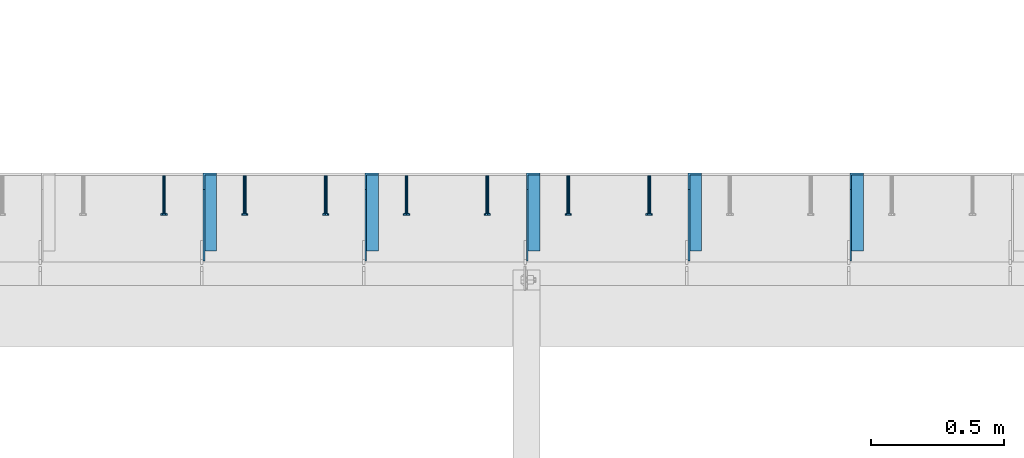
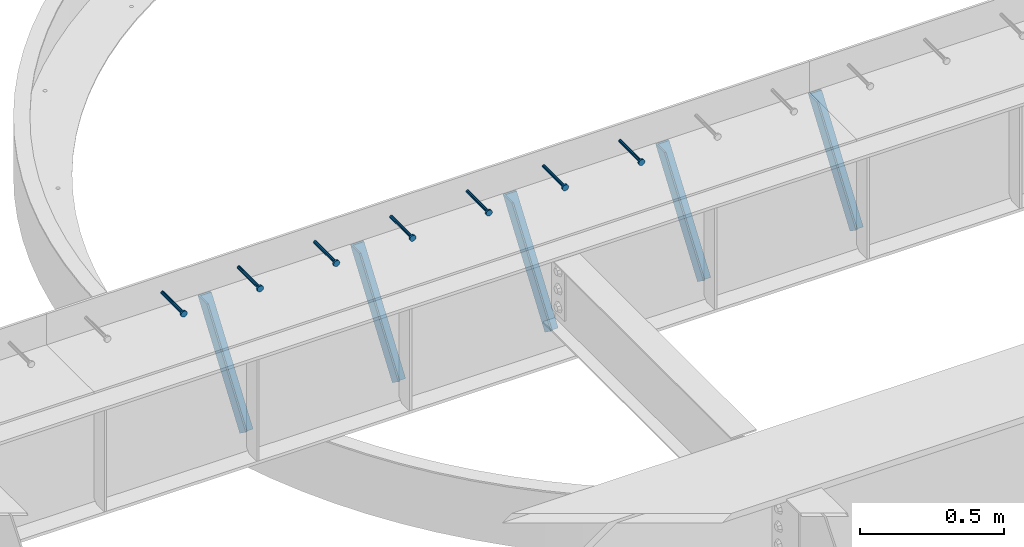
# One storey, part 1349 of 1763: 7 beams, 5 members, 8 elements without a shape of their own.
"""IFC2X3 building model written with IfcOpenShell, lengths in millimetres."""

from ifc_helpers import new_model, si_unit, frame, origin_with_axes, place, context, subcontext, project, spatial, faceted_brep, material, type_object, element, aggregate, save


model = new_model("IFC2X3")

# Units and contexts
model_context = context("Model", 3, precision=1e-05, world=origin_with_axes())
body_context = subcontext(model_context, "Body", "Model", "MODEL_VIEW")
ifc_project = project(units=[si_unit("LENGTHUNIT", "METRE", prefix="MILLI"), si_unit("AREAUNIT", "SQUARE_METRE"), si_unit("VOLUMEUNIT", "CUBIC_METRE"), si_unit("MASSUNIT", "GRAM", prefix="KILO"), si_unit("TIMEUNIT", "SECOND"), si_unit("PLANEANGLEUNIT", "RADIAN"), si_unit("SOLIDANGLEUNIT", "STERADIAN"), si_unit("THERMODYNAMICTEMPERATUREUNIT", "DEGREE_CELSIUS"), si_unit("LUMINOUSINTENSITYUNIT", "LUMEN")], contexts=[model_context])

# Site, building, storey
site_placement = place(None, origin_with_axes())
site = spatial("IfcSite", under=ifc_project, at=site_placement, CompositionType="ELEMENT")
building_placement = place(site_placement, origin_with_axes())
building = spatial("IfcBuilding", under=site, at=building_placement, Name="Undefined", CompositionType="ELEMENT")
storey_placement = place(building_placement, origin_with_axes())
storey = spatial("IfcBuildingStorey", under=building, at=storey_placement, Name="Undefined", CompositionType="ELEMENT", Elevation=0.0)

# Assembly, beam
assembly_1_placement = place(storey_placement, origin_with_axes())
assembly_1 = element("IfcElementAssembly", 1, at=assembly_1_placement, inside=storey, Name="HEADED STUD ANCHOR", AssemblyPlace="NOTDEFINED", PredefinedType="RIGID_FRAME")
ifc_material_1 = material(Name="STEEL/A108")
beam_type = type_object("IfcBeamType", PredefinedType="NOTDEFINED")
beam_1_placement = place(assembly_1_placement, frame((-56255.6747736983, 53984.5250183106, 5264.23140606069), z_axis=(0.0, 0.0, 1.0), x_axis=(0.0, -1.0, 0.0)))
beam_1 = element("IfcBeam", 2, at=beam_1_placement, type_object=beam_type, material=ifc_material_1, Name="HEADED STUD ANCHOR", context=body_context, shape_type="Brep", body=[
    faceted_brep([(0.0, -3.1800000667572, 5.5), (0.0, -5.5, 3.1800000667572), (141.732000000002, -5.5, 3.1800000667572), (141.732000000002, -3.1800000667572, 5.5), (0.0, -6.34999999999491, 1.45519152283669e-11), (141.732000000002, -6.34999990463257, 0.0), (0.0, -5.5, -3.1800000667572), (141.732000000002, -5.5, -3.1800000667572), (0.0, -3.1800000667572, -5.5), (141.732000000002, -3.1800000667572, -5.5), (0.0, 0.0, -6.34999990463257), (141.732000000002, 0.0, -6.34999990463257), (0.0, 3.1800000667572, -5.5), (141.732000000002, 3.1800000667572, -5.5), (0.0, 5.5, -3.1800000667572), (141.732000000002, 5.5, -3.1800000667572), (0.0, 6.34999999999491, -2.91038304567337e-11), (141.732000000002, 6.34999990463257, 0.0), (0.0, 5.5, 3.1800000667572), (141.732000000002, 5.5, 3.1800000667572), (0.0, 3.1800000667572, 5.5), (141.732000000002, 3.1800000667572, 5.5), (0.0, 0.0, 6.34999990463257), (141.732000000002, 0.0, 6.34999990463257), (144.780000000001, -10.9899997711182, 6.34999990463257), (144.780000000001, -6.34000015258789, 10.9899997711182), (144.780000000001, -12.6999998092651, 0.0), (144.780000000001, -10.9899997711182, -6.34999990463257), (144.780000000001, -6.34000015258789, -10.9899997711182), (144.780000000001, 0.0, -12.6899995803833), (144.780000000001, 6.34000015258789, -10.9899997711182), (144.780000000001, 10.9899997711182, -6.34999990463257), (144.780000000001, 12.6999998092651, 0.0), (144.780000000001, 10.9899997711182, 6.34999990463257), (144.780000000001, 6.34000015258789, 10.9899997711182), (144.780000000001, 0.0, 12.6899995803833), (152.400000000001, -10.9899997711182, 6.34999990463257), (152.400000000001, -6.34000015258789, 10.9899997711182), (152.400000000001, -12.6999998092651, 0.0), (152.400000000001, -10.9899997711182, -6.34999990463257), (152.400000000001, -6.34000015258789, -10.9899997711182), (152.400000000001, 0.0, -12.6899995803833), (152.400000000001, 6.34000015258789, -10.9899997711182), (152.400000000001, 10.9899997711182, -6.34999990463257), (152.400000000001, 12.6999998092651, 0.0), (152.400000000001, 10.9899997711182, 6.34999990463257), (152.400000000001, 6.34000015258789, 10.9899997711182), (152.400000000001, 0.0, 12.6899995803833)], [[[0, 1, 2, 3]], [[1, 4, 5, 2]], [[4, 6, 7, 5]], [[6, 8, 9, 7]], [[8, 10, 11, 9]], [[10, 12, 13, 11]], [[12, 14, 15, 13]], [[14, 16, 17, 15]], [[16, 18, 19, 17]], [[18, 20, 21, 19]], [[20, 22, 23, 21]], [[22, 0, 3, 23]], [[22, 20, 18, 16, 14, 12, 10, 8, 6, 4, 1, 0]], [[3, 2, 24, 25]], [[2, 5, 26, 24]], [[5, 7, 27, 26]], [[7, 9, 28, 27]], [[9, 11, 29, 28]], [[11, 13, 30, 29]], [[13, 15, 31, 30]], [[15, 17, 32, 31]], [[17, 19, 33, 32]], [[19, 21, 34, 33]], [[21, 23, 35, 34]], [[23, 3, 25, 35]], [[25, 24, 36, 37]], [[24, 26, 38, 36]], [[26, 27, 39, 38]], [[27, 28, 40, 39]], [[28, 29, 41, 40]], [[29, 30, 42, 41]], [[30, 31, 43, 42]], [[31, 32, 44, 43]], [[32, 33, 45, 44]], [[33, 34, 46, 45]], [[34, 35, 47, 46]], [[35, 25, 37, 47]], [[38, 39, 40, 41, 42, 43, 44, 45, 46, 47, 37, 36]]]),
])
aggregate(assembly_1, [beam_1])

assembly_2_placement = place(storey_placement, origin_with_axes())
assembly_2 = element("IfcElementAssembly", 3, at=assembly_2_placement, inside=storey, Name="HEADED STUD ANCHOR", AssemblyPlace="NOTDEFINED", PredefinedType="RIGID_FRAME")
beam_2_placement = place(assembly_2_placement, frame((-56560.4747736983, 53984.5250183106, 5264.23140606069), z_axis=(0.0, 0.0, 1.0), x_axis=(0.0, -1.0, 0.0)))
beam_2 = element("IfcBeam", 4, at=beam_2_placement, type_object=beam_type, material=ifc_material_1, Name="HEADED STUD ANCHOR", context=body_context, shape_type="Brep", body=[
    faceted_brep([(0.0, -3.1800000667572, 5.5), (0.0, -5.5, 3.1800000667572), (141.732000000002, -5.5, 3.1800000667572), (141.732000000002, -3.1800000667572, 5.5), (0.0, -6.34999999999491, 1.45519152283669e-11), (141.732000000002, -6.34999990463257, 0.0), (0.0, -5.5, -3.1800000667572), (141.732000000002, -5.5, -3.1800000667572), (0.0, -3.1800000667572, -5.5), (141.732000000002, -3.1800000667572, -5.5), (0.0, 0.0, -6.34999990463257), (141.732000000002, 0.0, -6.34999990463257), (0.0, 3.1800000667572, -5.5), (141.732000000002, 3.1800000667572, -5.5), (0.0, 5.5, -3.1800000667572), (141.732000000002, 5.5, -3.1800000667572), (0.0, 6.34999999999491, -2.91038304567337e-11), (141.732000000002, 6.34999990463257, 0.0), (0.0, 5.5, 3.1800000667572), (141.732000000002, 5.5, 3.1800000667572), (0.0, 3.1800000667572, 5.5), (141.732000000002, 3.1800000667572, 5.5), (0.0, 0.0, 6.34999990463257), (141.732000000002, 0.0, 6.34999990463257), (144.780000000001, -10.9899997711182, 6.34999990463257), (144.780000000001, -6.34000015258789, 10.9899997711182), (144.780000000001, -12.6999998092651, 0.0), (144.780000000001, -10.9899997711182, -6.34999990463257), (144.780000000001, -6.34000015258789, -10.9899997711182), (144.780000000001, 0.0, -12.6899995803833), (144.780000000001, 6.34000015258789, -10.9899997711182), (144.780000000001, 10.9899997711182, -6.34999990463257), (144.780000000001, 12.6999998092651, 0.0), (144.780000000001, 10.9899997711182, 6.34999990463257), (144.780000000001, 6.34000015258789, 10.9899997711182), (144.780000000001, 0.0, 12.6899995803833), (152.400000000001, -10.9899997711182, 6.34999990463257), (152.400000000001, -6.34000015258789, 10.9899997711182), (152.400000000001, -12.6999998092651, 0.0), (152.400000000001, -10.9899997711182, -6.34999990463257), (152.400000000001, -6.34000015258789, -10.9899997711182), (152.400000000001, 0.0, -12.6899995803833), (152.400000000001, 6.34000015258789, -10.9899997711182), (152.400000000001, 10.9899997711182, -6.34999990463257), (152.400000000001, 12.6999998092651, 0.0), (152.400000000001, 10.9899997711182, 6.34999990463257), (152.400000000001, 6.34000015258789, 10.9899997711182), (152.400000000001, 0.0, 12.6899995803833)], [[[0, 1, 2, 3]], [[1, 4, 5, 2]], [[4, 6, 7, 5]], [[6, 8, 9, 7]], [[8, 10, 11, 9]], [[10, 12, 13, 11]], [[12, 14, 15, 13]], [[14, 16, 17, 15]], [[16, 18, 19, 17]], [[18, 20, 21, 19]], [[20, 22, 23, 21]], [[22, 0, 3, 23]], [[22, 20, 18, 16, 14, 12, 10, 8, 6, 4, 1, 0]], [[3, 2, 24, 25]], [[2, 5, 26, 24]], [[5, 7, 27, 26]], [[7, 9, 28, 27]], [[9, 11, 29, 28]], [[11, 13, 30, 29]], [[13, 15, 31, 30]], [[15, 17, 32, 31]], [[17, 19, 33, 32]], [[19, 21, 34, 33]], [[21, 23, 35, 34]], [[23, 3, 25, 35]], [[25, 24, 36, 37]], [[24, 26, 38, 36]], [[26, 27, 39, 38]], [[27, 28, 40, 39]], [[28, 29, 41, 40]], [[29, 30, 42, 41]], [[30, 31, 43, 42]], [[31, 32, 44, 43]], [[32, 33, 45, 44]], [[33, 34, 46, 45]], [[34, 35, 47, 46]], [[35, 25, 37, 47]], [[38, 39, 40, 41, 42, 43, 44, 45, 46, 47, 37, 36]]]),
])
aggregate(assembly_2, [beam_2])

assembly_3_placement = place(storey_placement, origin_with_axes())
assembly_3 = element("IfcElementAssembly", 5, at=assembly_3_placement, inside=storey, Name="HEADED STUD ANCHOR", AssemblyPlace="NOTDEFINED", PredefinedType="RIGID_FRAME")
beam_3_placement = place(assembly_3_placement, frame((-56865.2747736983, 53984.5250183106, 5264.23140606069), z_axis=(0.0, 0.0, 1.0), x_axis=(0.0, -1.0, 0.0)))
beam_3 = element("IfcBeam", 6, at=beam_3_placement, type_object=beam_type, material=ifc_material_1, Name="HEADED STUD ANCHOR", context=body_context, shape_type="Brep", body=[
    faceted_brep([(0.0, -3.1800000667572, 5.5), (0.0, -5.5, 3.1800000667572), (141.732000000002, -5.5, 3.1800000667572), (141.732000000002, -3.1800000667572, 5.5), (0.0, -6.34999999999491, 1.45519152283669e-11), (141.732000000002, -6.34999990463257, 0.0), (0.0, -5.5, -3.1800000667572), (141.732000000002, -5.5, -3.1800000667572), (0.0, -3.1800000667572, -5.5), (141.732000000002, -3.1800000667572, -5.5), (0.0, 0.0, -6.34999990463257), (141.732000000002, 0.0, -6.34999990463257), (0.0, 3.1800000667572, -5.5), (141.732000000002, 3.1800000667572, -5.5), (0.0, 5.5, -3.1800000667572), (141.732000000002, 5.5, -3.1800000667572), (0.0, 6.34999999999491, -2.91038304567337e-11), (141.732000000002, 6.34999990463257, 0.0), (0.0, 5.5, 3.1800000667572), (141.732000000002, 5.5, 3.1800000667572), (0.0, 3.1800000667572, 5.5), (141.732000000002, 3.1800000667572, 5.5), (0.0, 0.0, 6.34999990463257), (141.732000000002, 0.0, 6.34999990463257), (144.780000000001, -10.9899997711182, 6.34999990463257), (144.780000000001, -6.34000015258789, 10.9899997711182), (144.780000000001, -12.6999998092651, 0.0), (144.780000000001, -10.9899997711182, -6.34999990463257), (144.780000000001, -6.34000015258789, -10.9899997711182), (144.780000000001, 0.0, -12.6899995803833), (144.780000000001, 6.34000015258789, -10.9899997711182), (144.780000000001, 10.9899997711182, -6.34999990463257), (144.780000000001, 12.6999998092651, 0.0), (144.780000000001, 10.9899997711182, 6.34999990463257), (144.780000000001, 6.34000015258789, 10.9899997711182), (144.780000000001, 0.0, 12.6899995803833), (152.400000000001, -10.9899997711182, 6.34999990463257), (152.400000000001, -6.34000015258789, 10.9899997711182), (152.400000000001, -12.6999998092651, 0.0), (152.400000000001, -10.9899997711182, -6.34999990463257), (152.400000000001, -6.34000015258789, -10.9899997711182), (152.400000000001, 0.0, -12.6899995803833), (152.400000000001, 6.34000015258789, -10.9899997711182), (152.400000000001, 10.9899997711182, -6.34999990463257), (152.400000000001, 12.6999998092651, 0.0), (152.400000000001, 10.9899997711182, 6.34999990463257), (152.400000000001, 6.34000015258789, 10.9899997711182), (152.400000000001, 0.0, 12.6899995803833)], [[[0, 1, 2, 3]], [[1, 4, 5, 2]], [[4, 6, 7, 5]], [[6, 8, 9, 7]], [[8, 10, 11, 9]], [[10, 12, 13, 11]], [[12, 14, 15, 13]], [[14, 16, 17, 15]], [[16, 18, 19, 17]], [[18, 20, 21, 19]], [[20, 22, 23, 21]], [[22, 0, 3, 23]], [[22, 20, 18, 16, 14, 12, 10, 8, 6, 4, 1, 0]], [[3, 2, 24, 25]], [[2, 5, 26, 24]], [[5, 7, 27, 26]], [[7, 9, 28, 27]], [[9, 11, 29, 28]], [[11, 13, 30, 29]], [[13, 15, 31, 30]], [[15, 17, 32, 31]], [[17, 19, 33, 32]], [[19, 21, 34, 33]], [[21, 23, 35, 34]], [[23, 3, 25, 35]], [[25, 24, 36, 37]], [[24, 26, 38, 36]], [[26, 27, 39, 38]], [[27, 28, 40, 39]], [[28, 29, 41, 40]], [[29, 30, 42, 41]], [[30, 31, 43, 42]], [[31, 32, 44, 43]], [[32, 33, 45, 44]], [[33, 34, 46, 45]], [[34, 35, 47, 46]], [[35, 25, 37, 47]], [[38, 39, 40, 41, 42, 43, 44, 45, 46, 47, 37, 36]]]),
])
aggregate(assembly_3, [beam_3])

assembly_4_placement = place(storey_placement, origin_with_axes())
assembly_4 = element("IfcElementAssembly", 7, at=assembly_4_placement, inside=storey, Name="HEADED STUD ANCHOR", AssemblyPlace="NOTDEFINED", PredefinedType="RIGID_FRAME")
beam_4_placement = place(assembly_4_placement, frame((-57170.0747736983, 53984.5250183106, 5264.23140606069), z_axis=(0.0, 0.0, 1.0), x_axis=(0.0, -1.0, 0.0)))
beam_4 = element("IfcBeam", 8, at=beam_4_placement, type_object=beam_type, material=ifc_material_1, Name="HEADED STUD ANCHOR", context=body_context, shape_type="Brep", body=[
    faceted_brep([(0.0, -3.1800000667572, 5.5), (0.0, -5.5, 3.1800000667572), (141.732000000002, -5.5, 3.1800000667572), (141.732000000002, -3.1800000667572, 5.5), (0.0, -6.34999999999491, 1.45519152283669e-11), (141.732000000002, -6.34999990463257, 0.0), (0.0, -5.5, -3.1800000667572), (141.732000000002, -5.5, -3.1800000667572), (0.0, -3.1800000667572, -5.5), (141.732000000002, -3.1800000667572, -5.5), (0.0, 0.0, -6.34999990463257), (141.732000000002, 0.0, -6.34999990463257), (0.0, 3.1800000667572, -5.5), (141.732000000002, 3.1800000667572, -5.5), (0.0, 5.5, -3.1800000667572), (141.732000000002, 5.5, -3.1800000667572), (0.0, 6.34999999999491, -2.91038304567337e-11), (141.732000000002, 6.34999990463257, 0.0), (0.0, 5.5, 3.1800000667572), (141.732000000002, 5.5, 3.1800000667572), (0.0, 3.1800000667572, 5.5), (141.732000000002, 3.1800000667572, 5.5), (0.0, 0.0, 6.34999990463257), (141.732000000002, 0.0, 6.34999990463257), (144.780000000001, -10.9899997711182, 6.34999990463257), (144.780000000001, -6.34000015258789, 10.9899997711182), (144.780000000001, -12.6999998092651, 0.0), (144.780000000001, -10.9899997711182, -6.34999990463257), (144.780000000001, -6.34000015258789, -10.9899997711182), (144.780000000001, 0.0, -12.6899995803833), (144.780000000001, 6.34000015258789, -10.9899997711182), (144.780000000001, 10.9899997711182, -6.34999990463257), (144.780000000001, 12.6999998092651, 0.0), (144.780000000001, 10.9899997711182, 6.34999990463257), (144.780000000001, 6.34000015258789, 10.9899997711182), (144.780000000001, 0.0, 12.6899995803833), (152.400000000001, -10.9899997711182, 6.34999990463257), (152.400000000001, -6.34000015258789, 10.9899997711182), (152.400000000001, -12.6999998092651, 0.0), (152.400000000001, -10.9899997711182, -6.34999990463257), (152.400000000001, -6.34000015258789, -10.9899997711182), (152.400000000001, 0.0, -12.6899995803833), (152.400000000001, 6.34000015258789, -10.9899997711182), (152.400000000001, 10.9899997711182, -6.34999990463257), (152.400000000001, 12.6999998092651, 0.0), (152.400000000001, 10.9899997711182, 6.34999990463257), (152.400000000001, 6.34000015258789, 10.9899997711182), (152.400000000001, 0.0, 12.6899995803833)], [[[0, 1, 2, 3]], [[1, 4, 5, 2]], [[4, 6, 7, 5]], [[6, 8, 9, 7]], [[8, 10, 11, 9]], [[10, 12, 13, 11]], [[12, 14, 15, 13]], [[14, 16, 17, 15]], [[16, 18, 19, 17]], [[18, 20, 21, 19]], [[20, 22, 23, 21]], [[22, 0, 3, 23]], [[22, 20, 18, 16, 14, 12, 10, 8, 6, 4, 1, 0]], [[3, 2, 24, 25]], [[2, 5, 26, 24]], [[5, 7, 27, 26]], [[7, 9, 28, 27]], [[9, 11, 29, 28]], [[11, 13, 30, 29]], [[13, 15, 31, 30]], [[15, 17, 32, 31]], [[17, 19, 33, 32]], [[19, 21, 34, 33]], [[21, 23, 35, 34]], [[23, 3, 25, 35]], [[25, 24, 36, 37]], [[24, 26, 38, 36]], [[26, 27, 39, 38]], [[27, 28, 40, 39]], [[28, 29, 41, 40]], [[29, 30, 42, 41]], [[30, 31, 43, 42]], [[31, 32, 44, 43]], [[32, 33, 45, 44]], [[33, 34, 46, 45]], [[34, 35, 47, 46]], [[35, 25, 37, 47]], [[38, 39, 40, 41, 42, 43, 44, 45, 46, 47, 37, 36]]]),
])
aggregate(assembly_4, [beam_4])

assembly_5_placement = place(storey_placement, origin_with_axes())
assembly_5 = element("IfcElementAssembly", 9, at=assembly_5_placement, inside=storey, Name="HEADED STUD ANCHOR", AssemblyPlace="NOTDEFINED", PredefinedType="RIGID_FRAME")
beam_5_placement = place(assembly_5_placement, frame((-57474.8747736983, 53984.5250183106, 5264.23140606069), z_axis=(0.0, 0.0, 1.0), x_axis=(0.0, -1.0, 0.0)))
beam_5 = element("IfcBeam", 10, at=beam_5_placement, type_object=beam_type, material=ifc_material_1, Name="HEADED STUD ANCHOR", context=body_context, shape_type="Brep", body=[
    faceted_brep([(0.0, -3.1800000667572, 5.5), (0.0, -5.5, 3.1800000667572), (141.732000000002, -5.5, 3.1800000667572), (141.732000000002, -3.1800000667572, 5.5), (0.0, -6.34999999999491, 1.45519152283669e-11), (141.732000000002, -6.34999990463257, 0.0), (0.0, -5.5, -3.1800000667572), (141.732000000002, -5.5, -3.1800000667572), (0.0, -3.1800000667572, -5.5), (141.732000000002, -3.1800000667572, -5.5), (0.0, 0.0, -6.34999990463257), (141.732000000002, 0.0, -6.34999990463257), (0.0, 3.1800000667572, -5.5), (141.732000000002, 3.1800000667572, -5.5), (0.0, 5.5, -3.1800000667572), (141.732000000002, 5.5, -3.1800000667572), (0.0, 6.34999999999491, -2.91038304567337e-11), (141.732000000002, 6.34999990463257, 0.0), (0.0, 5.5, 3.1800000667572), (141.732000000002, 5.5, 3.1800000667572), (0.0, 3.1800000667572, 5.5), (141.732000000002, 3.1800000667572, 5.5), (0.0, 0.0, 6.34999990463257), (141.732000000002, 0.0, 6.34999990463257), (144.780000000001, -10.9899997711182, 6.34999990463257), (144.780000000001, -6.34000015258789, 10.9899997711182), (144.780000000001, -12.6999998092651, 0.0), (144.780000000001, -10.9899997711182, -6.34999990463257), (144.780000000001, -6.34000015258789, -10.9899997711182), (144.780000000001, 0.0, -12.6899995803833), (144.780000000001, 6.34000015258789, -10.9899997711182), (144.780000000001, 10.9899997711182, -6.34999990463257), (144.780000000001, 12.6999998092651, 0.0), (144.780000000001, 10.9899997711182, 6.34999990463257), (144.780000000001, 6.34000015258789, 10.9899997711182), (144.780000000001, 0.0, 12.6899995803833), (152.400000000001, -10.9899997711182, 6.34999990463257), (152.400000000001, -6.34000015258789, 10.9899997711182), (152.400000000001, -12.6999998092651, 0.0), (152.400000000001, -10.9899997711182, -6.34999990463257), (152.400000000001, -6.34000015258789, -10.9899997711182), (152.400000000001, 0.0, -12.6899995803833), (152.400000000001, 6.34000015258789, -10.9899997711182), (152.400000000001, 10.9899997711182, -6.34999990463257), (152.400000000001, 12.6999998092651, 0.0), (152.400000000001, 10.9899997711182, 6.34999990463257), (152.400000000001, 6.34000015258789, 10.9899997711182), (152.400000000001, 0.0, 12.6899995803833)], [[[0, 1, 2, 3]], [[1, 4, 5, 2]], [[4, 6, 7, 5]], [[6, 8, 9, 7]], [[8, 10, 11, 9]], [[10, 12, 13, 11]], [[12, 14, 15, 13]], [[14, 16, 17, 15]], [[16, 18, 19, 17]], [[18, 20, 21, 19]], [[20, 22, 23, 21]], [[22, 0, 3, 23]], [[22, 20, 18, 16, 14, 12, 10, 8, 6, 4, 1, 0]], [[3, 2, 24, 25]], [[2, 5, 26, 24]], [[5, 7, 27, 26]], [[7, 9, 28, 27]], [[9, 11, 29, 28]], [[11, 13, 30, 29]], [[13, 15, 31, 30]], [[15, 17, 32, 31]], [[17, 19, 33, 32]], [[19, 21, 34, 33]], [[21, 23, 35, 34]], [[23, 3, 25, 35]], [[25, 24, 36, 37]], [[24, 26, 38, 36]], [[26, 27, 39, 38]], [[27, 28, 40, 39]], [[28, 29, 41, 40]], [[29, 30, 42, 41]], [[30, 31, 43, 42]], [[31, 32, 44, 43]], [[32, 33, 45, 44]], [[33, 34, 46, 45]], [[34, 35, 47, 46]], [[35, 25, 37, 47]], [[38, 39, 40, 41, 42, 43, 44, 45, 46, 47, 37, 36]]]),
])
aggregate(assembly_5, [beam_5])

assembly_6_placement = place(storey_placement, origin_with_axes())
assembly_6 = element("IfcElementAssembly", 11, at=assembly_6_placement, inside=storey, Name="HEADED STUD ANCHOR", AssemblyPlace="NOTDEFINED", PredefinedType="RIGID_FRAME")
beam_6_placement = place(assembly_6_placement, frame((-57779.6747736983, 53984.5250183106, 5264.23140606069), z_axis=(0.0, 0.0, 1.0), x_axis=(0.0, -1.0, 0.0)))
beam_6 = element("IfcBeam", 12, at=beam_6_placement, type_object=beam_type, material=ifc_material_1, Name="HEADED STUD ANCHOR", context=body_context, shape_type="Brep", body=[
    faceted_brep([(0.0, -3.1800000667572, 5.5), (0.0, -5.5, 3.1800000667572), (141.732000000002, -5.5, 3.1800000667572), (141.732000000002, -3.1800000667572, 5.5), (0.0, -6.34999999999491, 1.45519152283669e-11), (141.732000000002, -6.34999990463257, 0.0), (0.0, -5.5, -3.1800000667572), (141.732000000002, -5.5, -3.1800000667572), (0.0, -3.1800000667572, -5.5), (141.732000000002, -3.1800000667572, -5.5), (0.0, 0.0, -6.34999990463257), (141.732000000002, 0.0, -6.34999990463257), (0.0, 3.1800000667572, -5.5), (141.732000000002, 3.1800000667572, -5.5), (0.0, 5.5, -3.1800000667572), (141.732000000002, 5.5, -3.1800000667572), (0.0, 6.34999999999491, -2.91038304567337e-11), (141.732000000002, 6.34999990463257, 0.0), (0.0, 5.5, 3.1800000667572), (141.732000000002, 5.5, 3.1800000667572), (0.0, 3.1800000667572, 5.5), (141.732000000002, 3.1800000667572, 5.5), (0.0, 0.0, 6.34999990463257), (141.732000000002, 0.0, 6.34999990463257), (144.780000000001, -10.9899997711182, 6.34999990463257), (144.780000000001, -6.34000015258789, 10.9899997711182), (144.780000000001, -12.6999998092651, 0.0), (144.780000000001, -10.9899997711182, -6.34999990463257), (144.780000000001, -6.34000015258789, -10.9899997711182), (144.780000000001, 0.0, -12.6899995803833), (144.780000000001, 6.34000015258789, -10.9899997711182), (144.780000000001, 10.9899997711182, -6.34999990463257), (144.780000000001, 12.6999998092651, 0.0), (144.780000000001, 10.9899997711182, 6.34999990463257), (144.780000000001, 6.34000015258789, 10.9899997711182), (144.780000000001, 0.0, 12.6899995803833), (152.400000000001, -10.9899997711182, 6.34999990463257), (152.400000000001, -6.34000015258789, 10.9899997711182), (152.400000000001, -12.6999998092651, 0.0), (152.400000000001, -10.9899997711182, -6.34999990463257), (152.400000000001, -6.34000015258789, -10.9899997711182), (152.400000000001, 0.0, -12.6899995803833), (152.400000000001, 6.34000015258789, -10.9899997711182), (152.400000000001, 10.9899997711182, -6.34999990463257), (152.400000000001, 12.6999998092651, 0.0), (152.400000000001, 10.9899997711182, 6.34999990463257), (152.400000000001, 6.34000015258789, 10.9899997711182), (152.400000000001, 0.0, 12.6899995803833)], [[[0, 1, 2, 3]], [[1, 4, 5, 2]], [[4, 6, 7, 5]], [[6, 8, 9, 7]], [[8, 10, 11, 9]], [[10, 12, 13, 11]], [[12, 14, 15, 13]], [[14, 16, 17, 15]], [[16, 18, 19, 17]], [[18, 20, 21, 19]], [[20, 22, 23, 21]], [[22, 0, 3, 23]], [[22, 20, 18, 16, 14, 12, 10, 8, 6, 4, 1, 0]], [[3, 2, 24, 25]], [[2, 5, 26, 24]], [[5, 7, 27, 26]], [[7, 9, 28, 27]], [[9, 11, 29, 28]], [[11, 13, 30, 29]], [[13, 15, 31, 30]], [[15, 17, 32, 31]], [[17, 19, 33, 32]], [[19, 21, 34, 33]], [[21, 23, 35, 34]], [[23, 3, 25, 35]], [[25, 24, 36, 37]], [[24, 26, 38, 36]], [[26, 27, 39, 38]], [[27, 28, 40, 39]], [[28, 29, 41, 40]], [[29, 30, 42, 41]], [[30, 31, 43, 42]], [[31, 32, 44, 43]], [[32, 33, 45, 44]], [[33, 34, 46, 45]], [[34, 35, 47, 46]], [[35, 25, 37, 47]], [[38, 39, 40, 41, 42, 43, 44, 45, 46, 47, 37, 36]]]),
])
aggregate(assembly_6, [beam_6])

assembly_7_placement = place(storey_placement, origin_with_axes())
assembly_7 = element("IfcElementAssembly", 13, at=assembly_7_placement, inside=storey, Name="HEADED STUD ANCHOR", AssemblyPlace="NOTDEFINED", PredefinedType="RIGID_FRAME")
beam_7_placement = place(assembly_7_placement, frame((-58084.4747736983, 53984.5250183106, 5264.23140606069), z_axis=(0.0, 0.0, 1.0), x_axis=(0.0, -1.0, 0.0)))
beam_7 = element("IfcBeam", 14, at=beam_7_placement, type_object=beam_type, material=ifc_material_1, Name="HEADED STUD ANCHOR", context=body_context, shape_type="Brep", body=[
    faceted_brep([(0.0, -3.1800000667572, 5.5), (0.0, -5.5, 3.1800000667572), (141.732000000002, -5.5, 3.1800000667572), (141.732000000002, -3.1800000667572, 5.5), (0.0, -6.34999999999491, 1.45519152283669e-11), (141.732000000002, -6.34999990463257, 0.0), (0.0, -5.5, -3.1800000667572), (141.732000000002, -5.5, -3.1800000667572), (0.0, -3.1800000667572, -5.5), (141.732000000002, -3.1800000667572, -5.5), (0.0, 0.0, -6.34999990463257), (141.732000000002, 0.0, -6.34999990463257), (0.0, 3.1800000667572, -5.5), (141.732000000002, 3.1800000667572, -5.5), (0.0, 5.5, -3.1800000667572), (141.732000000002, 5.5, -3.1800000667572), (0.0, 6.34999999999491, -2.91038304567337e-11), (141.732000000002, 6.34999990463257, 0.0), (0.0, 5.5, 3.1800000667572), (141.732000000002, 5.5, 3.1800000667572), (0.0, 3.1800000667572, 5.5), (141.732000000002, 3.1800000667572, 5.5), (0.0, 0.0, 6.34999990463257), (141.732000000002, 0.0, 6.34999990463257), (144.780000000001, -10.9899997711182, 6.34999990463257), (144.780000000001, -6.34000015258789, 10.9899997711182), (144.780000000001, -12.6999998092651, 0.0), (144.780000000001, -10.9899997711182, -6.34999990463257), (144.780000000001, -6.34000015258789, -10.9899997711182), (144.780000000001, 0.0, -12.6899995803833), (144.780000000001, 6.34000015258789, -10.9899997711182), (144.780000000001, 10.9899997711182, -6.34999990463257), (144.780000000001, 12.6999998092651, 0.0), (144.780000000001, 10.9899997711182, 6.34999990463257), (144.780000000001, 6.34000015258789, 10.9899997711182), (144.780000000001, 0.0, 12.6899995803833), (152.400000000001, -10.9899997711182, 6.34999990463257), (152.400000000001, -6.34000015258789, 10.9899997711182), (152.400000000001, -12.6999998092651, 0.0), (152.400000000001, -10.9899997711182, -6.34999990463257), (152.400000000001, -6.34000015258789, -10.9899997711182), (152.400000000001, 0.0, -12.6899995803833), (152.400000000001, 6.34000015258789, -10.9899997711182), (152.400000000001, 10.9899997711182, -6.34999990463257), (152.400000000001, 12.6999998092651, 0.0), (152.400000000001, 10.9899997711182, 6.34999990463257), (152.400000000001, 6.34000015258789, 10.9899997711182), (152.400000000001, 0.0, 12.6899995803833)], [[[0, 1, 2, 3]], [[1, 4, 5, 2]], [[4, 6, 7, 5]], [[6, 8, 9, 7]], [[8, 10, 11, 9]], [[10, 12, 13, 11]], [[12, 14, 15, 13]], [[14, 16, 17, 15]], [[16, 18, 19, 17]], [[18, 20, 21, 19]], [[20, 22, 23, 21]], [[22, 0, 3, 23]], [[22, 20, 18, 16, 14, 12, 10, 8, 6, 4, 1, 0]], [[3, 2, 24, 25]], [[2, 5, 26, 24]], [[5, 7, 27, 26]], [[7, 9, 28, 27]], [[9, 11, 29, 28]], [[11, 13, 30, 29]], [[13, 15, 31, 30]], [[15, 17, 32, 31]], [[17, 19, 33, 32]], [[19, 21, 34, 33]], [[21, 23, 35, 34]], [[23, 3, 25, 35]], [[25, 24, 36, 37]], [[24, 26, 38, 36]], [[26, 27, 39, 38]], [[27, 28, 40, 39]], [[28, 29, 41, 40]], [[29, 30, 42, 41]], [[30, 31, 43, 42]], [[31, 32, 44, 43]], [[32, 33, 45, 44]], [[33, 34, 46, 45]], [[34, 35, 47, 46]], [[35, 25, 37, 47]], [[38, 39, 40, 41, 42, 43, 44, 45, 46, 47, 37, 36]]]),
])
aggregate(assembly_7, [beam_7])

# Assembly, members
assembly_8_placement = place(storey_placement, origin_with_axes())
assembly_8 = element("IfcElementAssembly", 15, at=assembly_8_placement, inside=storey, Name="BEAM", AssemblyPlace="NOTDEFINED", PredefinedType="RIGID_FRAME")
ifc_material_2 = material(Name="STEEL/A36")
member_type = type_object("IfcMemberType", Name="L2X2X1/4", PredefinedType="NOTDEFINED")
member_1_placement = place(assembly_8_placement, frame((-55473.0372736984, 53682.7083833992, 4801.551610525), z_axis=(0.0, -0.814117947745209, 0.580699549818259), x_axis=(0.0, 0.58069954981826, 0.814117947745209)))
member_1 = element("IfcMember", 16, at=member_1_placement, type_object=member_type, material=ifc_material_2, Name="ANGLE", ObjectType="L2X2X1/4", context=body_context, shape_type="Brep", body=[
    faceted_brep([(-1.45519152283669e-11, 25.4000000000015, -25.3999999999869), (1.45519152283669e-11, 25.4000000000015, 25.3999999999796), (464.304493432646, 25.4000000000015, 25.3999999991429), (500.539460322936, 25.4000000000015, -25.4000000009546), (1.45519152283669e-11, 19.0499999999993, 25.3999999999796), (464.304493432646, 19.0500000000029, 25.3999999991429), (-7.27595761418343e-12, 19.0499999999993, -19.0499999999956), (496.010089461648, 19.0500000000029, -19.0500000009415), (-7.27595761418343e-12, -25.4000000000015, -19.0499999999956), (496.010089461648, -25.4000000000015, -19.0500000009415), (-1.45519152283669e-11, -25.4000000000015, -25.3999999999869), (500.539460322936, -25.4000000000015, -25.4000000009546)], [[[0, 1, 2, 3]], [[1, 4, 5, 2]], [[4, 6, 7, 5]], [[6, 8, 9, 7]], [[8, 10, 11, 9]], [[10, 0, 3, 11]], [[5, 7, 9, 11, 3, 2]], [[10, 8, 6, 4, 1, 0]]]),
])
member_2_placement = place(assembly_8_placement, frame((-56692.2372736984, 53682.7083833992, 4801.551610525), z_axis=(0.0, -0.814117947745209, 0.580699549818259), x_axis=(0.0, 0.58069954981826, 0.814117947745209)))
member_2 = element("IfcMember", 17, at=member_2_placement, type_object=member_type, material=ifc_material_2, Name="ANGLE", ObjectType="L2X2X1/4", context=body_context, shape_type="Brep", body=[
    faceted_brep([(-1.45519152283669e-11, 25.4000000000015, -25.3999999999869), (1.45519152283669e-11, 25.4000000000015, 25.3999999999796), (464.304493432646, 25.4000000000015, 25.3999999991429), (500.539460322936, 25.4000000000015, -25.4000000009546), (1.45519152283669e-11, 19.0499999999993, 25.3999999999796), (464.304493432646, 19.0500000000029, 25.3999999991429), (-7.27595761418343e-12, 19.0499999999993, -19.0499999999956), (496.010089461648, 19.0500000000029, -19.0500000009415), (-7.27595761418343e-12, -25.4000000000015, -19.0499999999956), (496.010089461648, -25.4000000000015, -19.0500000009415), (-1.45519152283669e-11, -25.4000000000015, -25.3999999999869), (500.539460322936, -25.4000000000015, -25.4000000009546)], [[[0, 1, 2, 3]], [[1, 4, 5, 2]], [[4, 6, 7, 5]], [[6, 8, 9, 7]], [[8, 10, 11, 9]], [[10, 0, 3, 11]], [[5, 7, 9, 11, 3, 2]], [[10, 8, 6, 4, 1, 0]]]),
])
member_3_placement = place(assembly_8_placement, frame((-57911.4372736983, 53682.7083833992, 4801.551610525), z_axis=(0.0, -0.814117947745209, 0.580699549818259), x_axis=(0.0, 0.58069954981826, 0.814117947745209)))
member_3 = element("IfcMember", 18, at=member_3_placement, type_object=member_type, material=ifc_material_2, Name="ANGLE", ObjectType="L2X2X1/4", context=body_context, shape_type="Brep", body=[
    faceted_brep([(-1.45519152283669e-11, 25.4000000000015, -25.3999999999869), (1.45519152283669e-11, 25.4000000000015, 25.3999999999796), (464.304493432646, 25.4000000000015, 25.3999999991429), (500.539460322936, 25.4000000000015, -25.4000000009546), (1.45519152283669e-11, 19.0499999999993, 25.3999999999796), (464.304493432646, 19.0500000000029, 25.3999999991429), (-7.27595761418343e-12, 19.0499999999993, -19.0499999999956), (496.010089461648, 19.0500000000029, -19.0500000009415), (-7.27595761418343e-12, -25.4000000000015, -19.0499999999956), (496.010089461648, -25.4000000000015, -19.0500000009415), (-1.45519152283669e-11, -25.4000000000015, -25.3999999999869), (500.539460322936, -25.4000000000015, -25.4000000009546)], [[[0, 1, 2, 3]], [[1, 4, 5, 2]], [[4, 6, 7, 5]], [[6, 8, 9, 7]], [[8, 10, 11, 9]], [[10, 0, 3, 11]], [[5, 7, 9, 11, 3, 2]], [[10, 8, 6, 4, 1, 0]]]),
])
member_4_placement = place(assembly_8_placement, frame((-56082.6372736984, 53682.7083833992, 4801.551610525), z_axis=(0.0, -0.814117947745209, 0.580699549818259), x_axis=(0.0, 0.58069954981826, 0.814117947745209)))
member_4 = element("IfcMember", 19, at=member_4_placement, type_object=member_type, material=ifc_material_2, Name="ANGLE", ObjectType="L2X2X1/4", context=body_context, shape_type="Brep", body=[
    faceted_brep([(-1.45519152283669e-11, 25.4000000000015, -25.3999999999869), (1.45519152283669e-11, 25.4000000000015, 25.3999999999796), (464.304493432646, 25.4000000000015, 25.3999999991429), (500.539460322936, 25.4000000000015, -25.4000000009546), (1.45519152283669e-11, 19.0499999999993, 25.3999999999796), (464.304493432646, 19.0500000000029, 25.3999999991429), (-7.27595761418343e-12, 19.0499999999993, -19.0499999999956), (496.010089461648, 19.0500000000029, -19.0500000009415), (-7.27595761418343e-12, -25.4000000000015, -19.0499999999956), (496.010089461648, -25.4000000000015, -19.0500000009415), (-1.45519152283669e-11, -25.4000000000015, -25.3999999999869), (500.539460322936, -25.4000000000015, -25.4000000009546)], [[[0, 1, 2, 3]], [[1, 4, 5, 2]], [[4, 6, 7, 5]], [[6, 8, 9, 7]], [[8, 10, 11, 9]], [[10, 0, 3, 11]], [[5, 7, 9, 11, 3, 2]], [[10, 8, 6, 4, 1, 0]]]),
])
member_5_placement = place(assembly_8_placement, frame((-57301.8372736984, 53682.7083833992, 4801.551610525), z_axis=(0.0, -0.814117947745209, 0.580699549818259), x_axis=(0.0, 0.58069954981826, 0.814117947745209)))
member_5 = element("IfcMember", 20, at=member_5_placement, type_object=member_type, material=ifc_material_2, Name="ANGLE", ObjectType="L2X2X1/4", context=body_context, shape_type="Brep", body=[
    faceted_brep([(-1.45519152283669e-11, 25.4000000000015, -25.3999999999869), (1.45519152283669e-11, 25.4000000000015, 25.3999999999796), (464.304493432646, 25.4000000000015, 25.3999999991429), (500.539460322936, 25.4000000000015, -25.4000000009546), (1.45519152283669e-11, 19.0499999999993, 25.3999999999796), (464.304493432646, 19.0500000000029, 25.3999999991429), (-7.27595761418343e-12, 19.0499999999993, -19.0499999999956), (496.010089461648, 19.0500000000029, -19.0500000009415), (-7.27595761418343e-12, -25.4000000000015, -19.0499999999956), (496.010089461648, -25.4000000000015, -19.0500000009415), (-1.45519152283669e-11, -25.4000000000015, -25.3999999999869), (500.539460322936, -25.4000000000015, -25.4000000009546)], [[[0, 1, 2, 3]], [[1, 4, 5, 2]], [[4, 6, 7, 5]], [[6, 8, 9, 7]], [[8, 10, 11, 9]], [[10, 0, 3, 11]], [[5, 7, 9, 11, 3, 2]], [[10, 8, 6, 4, 1, 0]]]),
])
aggregate(assembly_8, [member_1, member_2, member_3, member_4, member_5])

save(model, "model.ifc")
